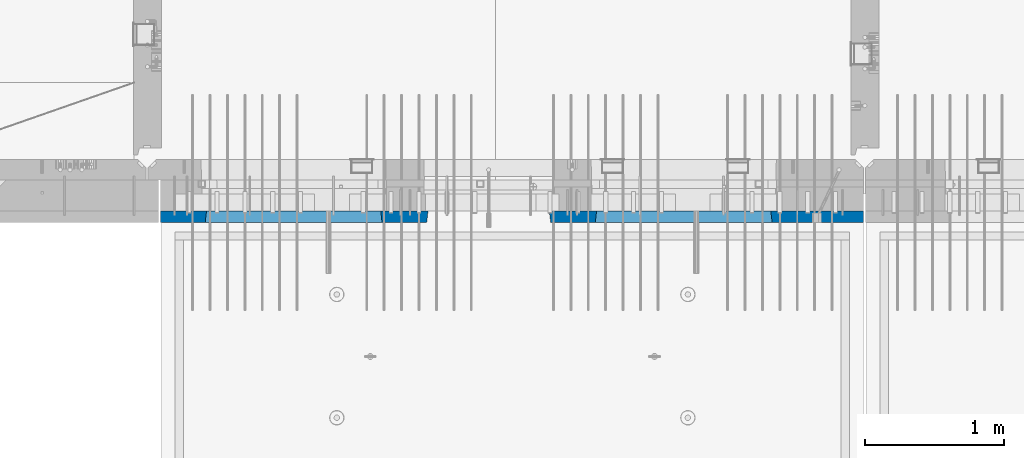
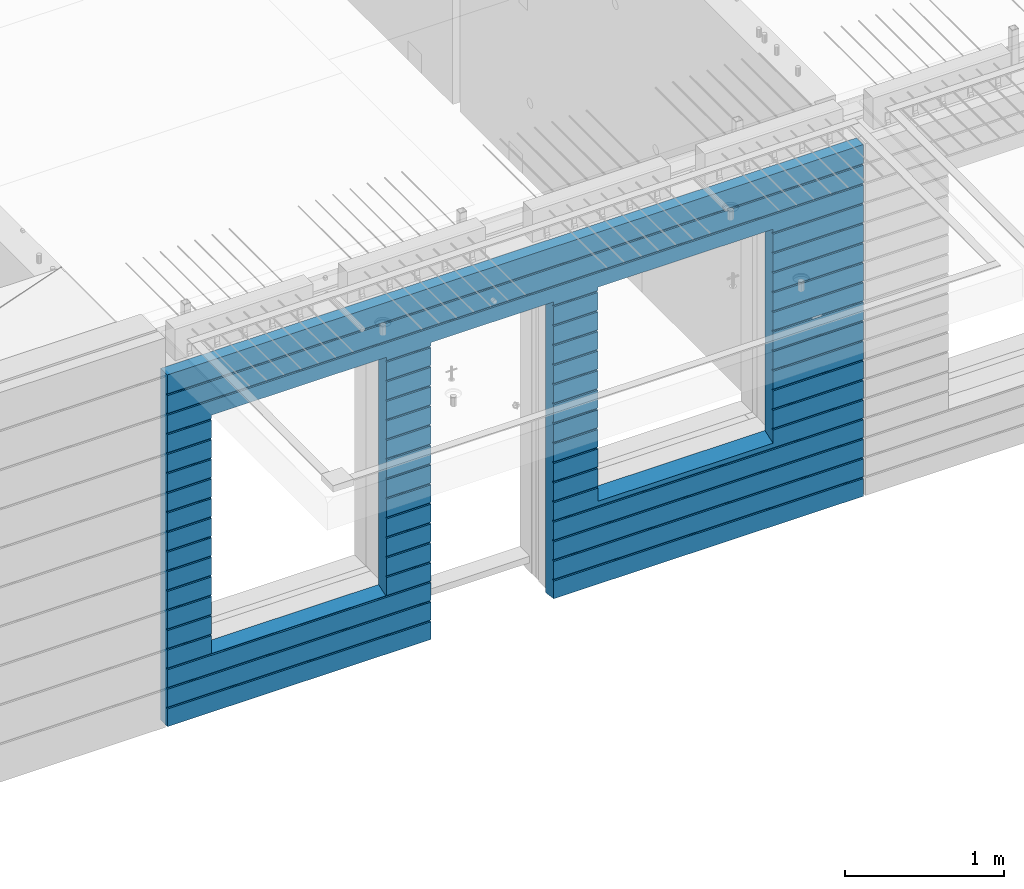
# One storey, part 222 of 341: 1 wall, 1 element without a shape of its own.
"""IFC2X3 building model written with IfcOpenShell, lengths in millimetres."""

import ifcopenshell
import ifcopenshell.guid

model = None  # the IFC model being written
_history = None  # IfcOwnerHistory: only IFC2X3 demands one
_inside = {}  # id of a spatial element -> (the spatial element, [elements in it])
_under = {}  # id of a project, library or spatial element -> (it, [spatial elements below it])
_declared = {}  # id of a project -> (the project, [libraries it declares])
_typed = {}  # id of a type object -> (the type object, [elements of that type])
_made_of = {}  # id of a material, layer set ... -> (it, [elements and type objects made of it])


def new_model(schema):
    """Start an empty IFC model of exactly this schema.

    Asked for "IFC4X3", IfcOpenShell would pick the latest addendum, in which some entities
    have other attributes; the version numbers below select the first issue.
    IFC2X3 requires an IfcOwnerHistory on every rooted entity: one is made here for all.
    """
    global model, _history
    if schema == "IFC4X3":
        model = ifcopenshell.file(schema_version=(4, 3, 0, 0))
    else:
        model = ifcopenshell.file(schema=schema)
    _inside.clear()
    _under.clear()
    _declared.clear()
    _typed.clear()
    _made_of.clear()
    _history = None
    if model.schema == "IFC2X3":
        org = make("IfcOrganization", Name="unknown")
        user = make(
            "IfcPersonAndOrganization",
            ThePerson=make("IfcPerson", FamilyName="unknown"),
            TheOrganization=org,
        )
        app = make(
            "IfcApplication",
            ApplicationDeveloper=org,
            Version="unknown",
            ApplicationFullName="unknown",
            ApplicationIdentifier="unknown",
        )
        _history = make(
            "IfcOwnerHistory",
            OwningUser=user,
            OwningApplication=app,
            ChangeAction="ADDED",
            CreationDate=0,
        )
    return model


def make(cls, **values):
    """One entity of the class cls with the attributes given. An attribute that is None is left unset."""
    return model.create_entity(
        cls, **{name: value for name, value in values.items() if value is not None}
    )


def rooted(cls, **values):
    """An entity with a GlobalId (a new one), such as an element, a storey or a relation."""
    return make(cls, GlobalId=ifcopenshell.guid.new(), OwnerHistory=_history, **values)


def si_unit(unit_type, name, prefix=None):
    """IfcSIUnit, for example si_unit("LENGTHUNIT", "METRE", prefix="MILLI")."""
    return make("IfcSIUnit", UnitType=unit_type, Prefix=prefix, Name=name)


def assignment(units):
    """IfcUnitAssignment: the units of a project."""
    return None if units is None else make("IfcUnitAssignment", Units=units)


def point(xyz):
    """IfcCartesianPoint."""
    return None if xyz is None else make("IfcCartesianPoint", Coordinates=xyz)


def direction(xyz):
    """IfcDirection."""
    return None if xyz is None else make("IfcDirection", DirectionRatios=xyz)


def frame(location, z_axis=None, x_axis=None):
    """IfcAxis2Placement3D, a coordinate frame: its origin and axes. An axis left out is left unset."""
    return make(
        "IfcAxis2Placement3D",
        Location=point(location),
        Axis=direction(z_axis),
        RefDirection=direction(x_axis),
    )


def origin_with_axes():
    """The frame at (0, 0, 0) with the z axis (0, 0, 1) and the x axis (1, 0, 0) written out."""
    return frame((0.0, 0.0, 0.0), z_axis=(0.0, 0.0, 1.0), x_axis=(1.0, 0.0, 0.0))


def place(relative_to, where):
    """IfcLocalPlacement: puts the frame where relative to a parent placement (None: the world)."""
    return make(
        "IfcLocalPlacement", PlacementRelTo=relative_to, RelativePlacement=where
    )


def context(
    kind, dimensions, precision=None, world=None, true_north=None, identifier=None
):
    """IfcGeometricRepresentationContext, for example the 3D "Model" context."""
    return make(
        "IfcGeometricRepresentationContext",
        ContextIdentifier=identifier,
        ContextType=kind,
        CoordinateSpaceDimension=dimensions,
        Precision=precision,
        WorldCoordinateSystem=world,
        TrueNorth=true_north,
    )


def subcontext(parent, identifier, kind, view, scale=None):
    """IfcGeometricRepresentationSubContext, for example "Body" below "Model"."""
    return make(
        "IfcGeometricRepresentationSubContext",
        ContextIdentifier=identifier,
        ContextType=kind,
        ParentContext=parent,
        TargetScale=scale,
        TargetView=view,
    )


def project(units=None, contexts=None):
    """IfcProject with its units and contexts."""
    return rooted(
        "IfcProject",
        Name="project",
        RepresentationContexts=contexts,
        UnitsInContext=assignment(units),
    )


def spatial(cls, under=None, at=None, **own):
    """A site, building, storey or space (cls), placed at a placement, below another one or the project."""
    s = rooted(cls, ObjectPlacement=at, **own)
    if under is not None:
        _under.setdefault(under.id(), (under, []))[1].append(s)
    return s


def faces_of(points, faces, orient=None, outer=None):
    """IfcFace entities. A face is a list of loops; a loop is a list of indices into points, from 0.

    orient and outer hold one flag for each loop. By default every Orientation is true, the
    first loop of a face is its IfcFaceOuterBound and the others are IfcFaceBound.
    """
    made = []
    for i, loops in enumerate(faces):
        bounds = []
        for j, loop in enumerate(loops):
            is_outer = j == 0 if outer is None else outer[i][j]
            bounds.append(
                make(
                    "IfcFaceOuterBound" if is_outer else "IfcFaceBound",
                    Bound=make("IfcPolyLoop", Polygon=[points[k] for k in loop]),
                    Orientation=True if orient is None else orient[i][j],
                )
            )
        made.append(make("IfcFace", Bounds=bounds))
    return made


def faceted_brep(points, faces, orient=None, outer=None, voids=None):
    """IfcFacetedBrep: a solid bounded by flat faces; with voids (closed shells), ...WithVoids."""
    shared = [point(p) for p in points]
    hull = make("IfcClosedShell", CfsFaces=faces_of(shared, faces, orient, outer))
    if voids is None:
        return make("IfcFacetedBrep", Outer=hull)
    return make(
        "IfcFacetedBrepWithVoids",
        Outer=hull,
        Voids=[
            make(cls, CfsFaces=faces_of(shared, fs, o, b)) for cls, fs, o, b in voids
        ],
    )


def shape(context_of_items, identifier, shape_type, items):
    """IfcShapeRepresentation: the items that make up one representation, for example the "Body"."""
    return make(
        "IfcShapeRepresentation",
        ContextOfItems=context_of_items,
        RepresentationIdentifier=identifier,
        RepresentationType=shape_type,
        Items=items,
    )


def material(Name=None, Category=None):
    """IfcMaterial."""
    return make("IfcMaterial", Name=Name, Category=Category)


def made_of(thing, what):
    """Note that an element or type object is made of a material, layer set ...; save() writes the relation."""
    if what is not None:
        _made_of.setdefault(what.id(), (what, []))[1].append(thing)
    return thing


def type_object(cls, material=None, **own):
    """A type object (cls), such as IfcWallType, which elements share."""
    return made_of(rooted(cls, **own), material)


def element(
    cls,
    number,
    at=None,
    inside=None,
    cuts=None,
    type_object=None,
    material=None,
    context=None,
    identifier="Body",
    shape_type=None,
    held_by="IfcProductDefinitionShape",
    body=None,
    shapes=None,
    **own,
):
    """One element of the class cls, such as IfcWall. Its Tag is "e" and its number.

    at: its placement. inside: the storey or other place that contains it. cuts: it is an
    opening in that element (IfcRelVoidsElement). A single representation is given by context,
    identifier, shape_type and body (its items); several are given by shapes. held_by: the class
    of the entity that holds the representations. save() writes the other relations.
    """
    e = rooted(cls, Tag="e%d" % number, ObjectPlacement=at, **own)
    if body is not None:
        shapes = [shape(context, identifier, shape_type, body)]
    if shapes is not None:
        e.Representation = make(held_by, Representations=shapes)
    if inside is not None:
        _inside.setdefault(inside.id(), (inside, []))[1].append(e)
    if cuts is not None:
        rooted(
            "IfcRelVoidsElement", RelatingBuildingElement=cuts, RelatedOpeningElement=e
        )
    if type_object is not None:
        _typed.setdefault(type_object.id(), (type_object, []))[1].append(e)
    return made_of(e, material)


def aggregate(whole, parts):
    """IfcRelAggregates: a whole, such as a stair, and the parts it consists of."""
    return rooted("IfcRelAggregates", RelatingObject=whole, RelatedObjects=parts)


def save(model, path):
    """Write the relations noted so far, then the file.

    IfcRelAggregates (storeys below a building ...), IfcRelContainedInSpatialStructure (elements
    in a storey), IfcRelDefinesByType, IfcRelAssociatesMaterial and IfcRelDeclares: one each for
    every whole, place, type object, material and project.
    """
    for whole, parts in _under.values():
        aggregate(whole, parts)
    for where, things in _inside.values():
        rooted(
            "IfcRelContainedInSpatialStructure",
            RelatedElements=things,
            RelatingStructure=where,
        )
    for kind, things in _typed.values():
        rooted("IfcRelDefinesByType", RelatedObjects=things, RelatingType=kind)
    for what, things in _made_of.values():
        rooted("IfcRelAssociatesMaterial", RelatedObjects=things, RelatingMaterial=what)
    for by, libraries in _declared.values():
        rooted("IfcRelDeclares", RelatingContext=by, RelatedDefinitions=libraries)
    model.write(path)


model = new_model("IFC2X3")

# Units and contexts
model_context = context("Model", 3, precision=1e-05, world=origin_with_axes())
body_context = subcontext(model_context, "Body", "Model", "MODEL_VIEW")
ifc_project = project(units=[si_unit("LENGTHUNIT", "METRE", prefix="MILLI"), si_unit("AREAUNIT", "SQUARE_METRE"), si_unit("VOLUMEUNIT", "CUBIC_METRE"), si_unit("MASSUNIT", "GRAM", prefix="KILO"), si_unit("TIMEUNIT", "SECOND"), si_unit("PLANEANGLEUNIT", "RADIAN"), si_unit("SOLIDANGLEUNIT", "STERADIAN"), si_unit("THERMODYNAMICTEMPERATUREUNIT", "DEGREE_CELSIUS"), si_unit("LUMINOUSINTENSITYUNIT", "LUMEN")], contexts=[model_context])

# Site, building, storey
site_placement = place(None, origin_with_axes())
site = spatial("IfcSite", under=ifc_project, at=site_placement, CompositionType="ELEMENT")
building_placement = place(site_placement, origin_with_axes())
building = spatial("IfcBuilding", under=site, at=building_placement, CompositionType="ELEMENT")
storey_placement = place(building_placement, origin_with_axes())
storey = spatial("IfcBuildingStorey", under=building, at=storey_placement, Name="5", CompositionType="ELEMENT", Elevation=0.0)

# Assembly, wall
assembly_placement = place(storey_placement, origin_with_axes())
assembly = element("IfcElementAssembly", 1, at=assembly_placement, inside=storey, AssemblyPlace="NOTDEFINED", PredefinedType="REINFORCEMENT_UNIT")
ifc_material = material(Name="CONCRETE/C30/37")
wall_type = type_object("IfcWallType", PredefinedType="NOTDEFINED")
wall_placement = place(assembly_placement, frame((21810.0, 7587.5, 95102.5), z_axis=(0.0, 0.0, 1.0), x_axis=(-1.0, 3.00000001838171e-08, 0.0)))
wall = element("IfcWall", 2, at=wall_placement, type_object=wall_type, material=ifc_material, context=body_context, shape_type="Brep", body=[
    faceted_brep([(3465.15088791894, 41.2121213860573, -911.742424344746), (3464.99937278789, 42.5, -912.5), (3464.99937278789, 42.5, -912.000000055254), (4734.84785765683, 41.2121213860573, -911.742424344746), (4734.99937278789, 42.5, -912.5), (4734.99937278789, 42.5, -912.000000055254), (10.0, 42.5, -1347.5), (10.0, 42.5, -1212.00000005524), (2254.99845837354, 42.5, -1212.00000005524), (2254.99845837354, 42.5, -1347.5), (10.0, 32.4999992501662, -1210.00000000079), (2256.17512512844, 32.4999992501662, -1210.00000000079), (10.0000007500639, 32.499999249937, -1200.00000000079), (2256.17512514468, 32.4999991121731, -1199.99999959956), (10.0, 42.5, -1198.00000011075), (2254.99845837354, 42.5, -1198.00000011075), (10.0, 42.5, -1062.00000005522), (2254.99845837354, 42.5, -1062.00000005522), (10.0, 32.4999992506964, -1060.00000000079), (2256.17512512838, 32.4999992506964, -1060.00000000079), (10.0000007500657, 32.499999249937, -1050.00000000079), (2256.17512514461, 32.499999112697, -1049.99999959956), (10.0, 42.5, -1048.00000011074), (2254.99845837354, 42.5, -1048.00000011074), (10.0, 42.5, -912.000000055254), (2254.99845837354, 42.5, -912.000000055254), (10.0, 32.4999992512312, -910.000000000815), (2256.17512512832, 32.4999992512312, -910.000000000815), (10.0000007500657, 32.499999249937, -900.000000000786), (2256.17512514455, 32.4999991132318, -899.99999959959), (10.0, 42.5, -898.000000110769), (2254.99845837354, 42.5, -898.000000110769), (10.0, 42.5, -762.000000055225), (2254.99845837354, 42.5, -762.000000055225), (10.0, 32.4999992517696, -760.000000000771), (2256.17512512825, 32.4999992517696, -760.000000000771), (10.0000007500657, 32.499999249937, -750.000000000786), (2256.17512514449, 32.4999991137747, -749.999999599546), (10.0, 42.5, -748.00000011074), (2254.99845837354, 42.5, -748.00000011074), (675.00013572734, 42.5, 927.5), (1925.00013572734, 42.5, 927.5), (1935.00013572734, 42.5, 927.5), (1925.00013572734, -42.5, 932.5), (675.00013572734, -42.5, 932.5), (665.00013572734, 42.5, 927.5), (665.00013572734, 42.5, -712.5), (675.00013572734, -42.5, -662.5), (1925.00013572734, -42.5, -662.5), (1935.00013572734, 42.5, -712.5), (1925.00013572734, -42.5, 927.5), (1935.00013572734, 42.5, 901.999999889245), (1933.82366503463, 32.4999991119776, 900.000000400425), (1933.82366505087, 32.4999992499834, 889.9999999992), (1935.00013572734, 42.5, 887.999999944761), (1935.00013572734, 42.5, 751.999999889245), (1933.82366503463, 32.4999991119885, 750.000000400425), (1933.82366505087, 32.4999992499925, 739.9999999992), (1935.00013572734, 42.5, 737.999999944761), (1935.00013572734, 42.5, 601.99999988926), (1933.82366503463, 32.4999991120112, 600.00000040044), (1933.82366505087, 32.4999992500152, 589.999999999214), (1935.00013572734, 42.5, 587.999999944775), (1935.00013572734, 42.5, 451.999999889245), (1933.82366503464, 32.4999991120167, 450.000000400425), (1933.82366505087, 32.4999992500216, 439.9999999992), (1935.00013572734, 42.5, 437.999999944761), (1935.00013572734, 42.5, 301.999999889245), (1933.82366503464, 32.4999991120312, 300.000000400425), (1933.82366505087, 32.4999992500352, 289.9999999992), (1935.00013572734, 42.5, 287.999999944761), (1935.00013572734, 42.5, 151.999999889245), (1933.82366503464, 32.4999991120421, 150.000000400425), (1933.82366505088, 32.499999250047, 139.9999999992), (1935.00013572734, 42.5, 137.999999944761), (1935.00013572734, 42.5, 1.99999988923082), (1933.82366503515, 32.4999991164286, 4.00410499423742e-07), (1933.82366505139, 32.4999992544263, -10.0000000008149), (1935.00013572734, 42.5, -12.0000000552536), (1935.00013572734, 42.5, -148.000000110755), (1933.82366503509, 32.4999991158993, -149.99999959956), (1933.82366505132, 32.4999992538915, -160.000000000786), (1935.00013572734, 42.5, -162.000000055239), (1935.00013572734, 42.5, -298.000000110755), (1933.82366503503, 32.49999911536, -299.999999599575), (1933.82366505126, 32.4999992533594, -310.0000000008), (1935.00013572734, 42.5, -312.000000055239), (1935.00013572734, 42.5, -448.00000011074), (1933.82366503496, 32.4999991148343, -449.99999959956), (1933.8236650512, 32.4999992528337, -460.000000000786), (1935.00013572734, 42.5, -462.000000055225), (1935.00013572734, 42.5, -598.000000110755), (1933.8236650349, 32.499999114295, -599.999999599575), (1933.82366505114, 32.4999992522935, -610.0000000008), (1935.00013572734, 42.5, -612.000000055239), (2256.1751251447, 32.4999991119776, 900.000000400425), (2256.17512512846, 32.4999992499834, 889.9999999992), (2254.99845837354, 42.5, 887.999999944761), (2254.99845837354, 42.5, 751.999999889245), (2256.17512514469, 32.4999991119885, 750.000000400425), (2256.17512512846, 32.4999992499925, 739.9999999992), (2254.99845837354, 42.5, 737.999999944761), (2254.99845837354, 42.5, 601.99999988926), (2256.17512514469, 32.4999991120112, 600.00000040044), (2256.17512512846, 32.4999992500152, 589.999999999214), (2254.99845837354, 42.5, 587.999999944775), (2254.99845837354, 42.5, 451.999999889245), (2256.17512514469, 32.4999991120167, 450.000000400425), (2256.17512512846, 32.4999992500216, 439.9999999992), (2254.99845837354, 42.5, 437.999999944761), (2254.99845837354, 42.5, 301.999999889245), (2256.17512514469, 32.4999991120312, 300.000000400425), (2256.17512512846, 32.4999992500352, 289.9999999992), (2254.99845837354, 42.5, 287.999999944761), (2254.99845837354, 42.5, 151.999999889245), (2256.17512514469, 32.4999991120421, 150.000000400425), (2256.17512512846, 32.499999250047, 139.9999999992), (2254.99845837354, 42.5, 137.999999944761), (2254.99845837354, 42.5, 1.99999988923082), (2256.17512514417, 32.4999991164286, 4.00410499423742e-07), (2256.17512512794, 32.4999992544263, -10.0000000008149), (2254.99845837354, 42.5, -12.0000000552536), (2254.99845837354, 42.5, -148.000000110755), (2256.17512514424, 32.4999991158993, -149.99999959956), (2256.175125128, 32.4999992538915, -160.000000000786), (2254.99845837354, 42.5, -162.000000055239), (2254.99845837354, 42.5, -298.000000110755), (2256.1751251443, 32.49999911536, -299.999999599575), (2256.17512512806, 32.4999992533594, -310.0000000008), (2254.99845837354, 42.5, -312.000000055239), (2254.99845837354, 42.5, -448.00000011074), (2256.17512514436, 32.4999991148343, -449.99999959956), (2256.17512512813, 32.4999992528337, -460.000000000786), (2254.99845837354, 42.5, -462.000000055225), (2254.99845837354, 42.5, -598.000000110755), (2256.17512514443, 32.499999114295, -599.999999599575), (2256.17512512819, 32.4999992522935, -610.0000000008), (2254.99845837354, 42.5, -612.000000055239), (10.0, 42.5, -612.000000055239), (665.00013572734, 42.5, -612.000000055239), (10.0, 32.4999992522935, -610.0000000008), (666.176606403544, 32.4999992522935, -610.0000000008), (10.0000007500657, 32.499999249937, -600.000000000786), (666.176606419776, 32.499999114295, -599.999999599575), (10.0, 42.5, -598.000000110755), (665.00013572734, 42.5, -598.000000110755), (10.0, 42.5, -462.000000055225), (665.00013572734, 42.5, -462.000000055225), (10.0, 32.4999992528337, -460.000000000786), (666.176606403482, 32.4999992528337, -460.000000000786), (10.0000007500657, 32.499999249937, -450.000000000786), (666.176606419715, 32.4999991148343, -449.99999959956), (10.0, 42.5, -448.00000011074), (665.00013572734, 42.5, -448.00000011074), (10.0, 42.5, -312.000000055239), (665.00013572734, 42.5, -312.000000055239), (10.0, 32.4999992533594, -310.0000000008), (666.17660640342, 32.4999992533594, -310.0000000008), (10.0000007500657, 32.499999249937, -300.000000000786), (666.176606419653, 32.49999911536, -299.999999599575), (10.0, 42.5, -298.000000110755), (665.00013572734, 42.5, -298.000000110755), (10.0, 42.5, -162.000000055239), (665.00013572734, 42.5, -162.000000055239), (10.0, 32.4999992538915, -160.000000000786), (666.176606403355, 32.4999992538915, -160.000000000786), (10.0000007500657, 32.499999249937, -150.000000000786), (666.176606419591, 32.4999991158993, -149.99999959956), (10.0, 42.5, -148.000000110755), (665.00013572734, 42.5, -148.000000110755), (10.0, 42.5, -12.0000000552536), (665.00013572734, 42.5, -12.0000000552536), (10.0, 32.4999992544263, -10.0000000008149), (666.176606403293, 32.4999992544263, -10.0000000008149), (10.0000007500657, 32.499999249937, -7.8580342233181e-10), (666.176606419529, 32.4999991164286, 4.00410499423742e-07), (10.0, 42.5, 1.99999988923082), (665.00013572734, 42.5, 1.99999988923082), (10.0, 42.5, 137.999999944761), (665.00013572734, 42.5, 137.999999944761), (10.0, 32.499999250047, 139.9999999992), (666.176606403806, 32.499999250047, 139.9999999992), (10.0000007500657, 32.499999249937, 149.999999999214), (666.176606420046, 32.4999991120421, 150.000000400425), (10.0, 42.5, 151.999999889245), (665.00013572734, 42.5, 151.999999889245), (10.0, 42.5, 287.999999944761), (665.00013572734, 42.5, 287.999999944761), (10.0, 32.4999992500352, 289.9999999992), (666.176606403809, 32.4999992500352, 289.9999999992), (10.0000007500657, 32.499999249937, 299.999999999214), (666.176606420046, 32.4999991120312, 300.000000400425), (10.0, 42.5, 301.999999889245), (665.00013572734, 42.5, 301.999999889245), (10.0, 42.5, 437.999999944761), (665.00013572734, 42.5, 437.999999944761), (10.0, 32.4999992500216, 439.9999999992), (666.176606403809, 32.4999992500216, 439.9999999992), (10.0000007500657, 32.499999249937, 449.999999999214), (666.176606420046, 32.4999991120167, 450.000000400425), (10.0, 42.5, 451.999999889245), (665.00013572734, 42.5, 451.999999889245), (10.0, 42.5, 587.999999944775), (665.00013572734, 42.5, 587.999999944775), (10.0, 32.4999992500152, 589.999999999214), (666.176606403809, 32.4999992500152, 589.999999999214), (10.0000007500657, 32.499999249937, 599.999999999214), (666.176606420049, 32.4999991120112, 600.00000040044), (10.0, 42.5, 601.99999988926), (665.00013572734, 42.5, 601.99999988926), (10.0, 42.5, 737.999999944761), (665.00013572734, 42.5, 737.999999944761), (9.99999999999636, 32.4999992499925, 739.9999999992), (666.176606403813, 32.4999992499925, 739.9999999992), (10.0000007500657, 32.499999249937, 749.999999999214), (666.176606420049, 32.4999991119885, 750.000000400425), (10.0, 42.5, 751.999999889245), (665.00013572734, 42.5, 751.999999889245), (10.0, 42.5, 887.999999944761), (665.00013572734, 42.5, 887.999999944761), (10.0, 32.4999992499834, 889.9999999992), (666.176606403813, 32.4999992499834, 889.9999999992), (10.0000007500657, 32.499999249937, 899.999999999214), (666.176606420053, 32.4999991119776, 900.000000400425), (675.00013572734, -42.5, 927.5), (665.00013572734, 42.5, 901.999999889245), (10.0, 42.5, 901.999999889245), (10.0, 42.5, 1051.99999988925), (5055.0, 42.5, 1051.99999988925), (5055.0, 32.4999991119666, 1050.00000040043), (10.0000007500657, 32.499999249937, 1049.99999999921), (5055.0, 32.4999992499706, 1039.9999999992), (10.0, 32.4999992499706, 1039.9999999992), (5055.0, 42.5, 1037.99999994476), (10.0, 42.5, 1037.99999994476), (5055.0, 42.5, 901.999999889245), (5055.0, 32.4999991119776, 900.000000400425), (4733.82290209518, 32.4999991119776, 900.000000400425), (4734.99937278789, 42.5, 901.999999889245), (5055.0, 32.4999992499834, 889.9999999992), (4733.82290211141, 32.4999992499834, 889.9999999992), (5055.0, 42.5, 887.999999944761), (4734.99937278789, 42.5, 887.999999944761), (5055.0, 42.5, 751.999999889245), (4734.99937278789, 42.5, 751.999999889245), (5055.0, 32.4999991119885, 750.000000400425), (4733.82290209518, 32.4999991119885, 750.000000400425), (5055.0, 32.4999992499925, 739.9999999992), (4733.82290211142, 32.4999992499925, 739.9999999992), (5055.0, 42.5, 737.999999944761), (4734.99937278789, 42.5, 737.999999944761), (5055.0, 42.5, 601.99999988926), (4734.99937278789, 42.5, 601.99999988926), (5055.0, 32.4999991120112, 600.00000040044), (4733.82290209518, 32.4999991120112, 600.00000040044), (5055.0, 32.4999992500152, 589.999999999214), (4733.82290211142, 32.4999992500152, 589.999999999214), (5055.0, 42.5, 587.999999944775), (4734.99937278789, 42.5, 587.999999944775), (5055.0, 42.5, 451.999999889245), (4734.99937278789, 42.5, 451.999999889245), (5055.0, 32.4999991120167, 450.000000400425), (4733.82290209518, 32.4999991120167, 450.000000400425), (5055.0, 32.4999992500216, 439.9999999992), (4733.82290211142, 32.4999992500216, 439.9999999992), (5055.0, 42.5, 437.999999944761), (4734.99937278789, 42.5, 437.999999944761), (5055.0, 42.5, 301.999999889245), (4734.99937278789, 42.5, 301.999999889245), (5055.0, 32.4999991120312, 300.000000400425), (4733.82290209518, 32.4999991120312, 300.000000400425), (5055.0, 32.4999992500352, 289.9999999992), (4733.82290211142, 32.4999992500352, 289.9999999992), (5055.0, 42.5, 287.999999944761), (4734.99937278789, 42.5, 287.999999944761), (5055.0, 42.5, 151.999999889245), (4734.99937278789, 42.5, 151.999999889245), (5055.0, 32.4999991120421, 150.000000400425), (4733.82290209519, 32.4999991120421, 150.000000400425), (5055.0, 32.499999250047, 139.9999999992), (4733.82290211142, 32.499999250047, 139.9999999992), (5055.0, 42.5, 137.999999944761), (4734.99937278789, 42.5, 137.999999944761), (5055.0, 42.5, 1.99999988923082), (4734.99937278789, 42.5, 1.99999988923082), (5055.0, 32.4999991164286, 4.00410499423742e-07), (4733.8229020957, 32.4999991164286, 4.00410499423742e-07), (5055.0, 32.4999992544263, -10.0000000008149), (4733.82290211194, 32.4999992544263, -10.0000000008149), (5055.0, 42.5, -12.0000000552536), (4734.99937278789, 42.5, -12.0000000552536), (5055.0, 42.5, -148.000000110755), (4734.99937278789, 42.5, -148.000000110755), (5055.0, 32.4999991158993, -149.99999959956), (4733.82290209564, 32.4999991158993, -149.99999959956), (5055.0, 32.4999992538915, -160.000000000786), (4733.82290211188, 32.4999992538915, -160.000000000786), (5055.0, 42.5, -162.000000055239), (4734.99937278789, 42.5, -162.000000055239), (5055.0, 42.5, -298.000000110755), (4734.99937278789, 42.5, -298.000000110755), (5055.0, 32.49999911536, -299.999999599575), (4733.82290209558, 32.49999911536, -299.999999599575), (5055.0, 32.4999992533594, -310.0000000008), (4733.82290211181, 32.4999992533594, -310.0000000008), (5055.0, 42.5, -312.000000055239), (4734.99937278789, 42.5, -312.000000055239), (5055.0, 42.5, -448.00000011074), (4734.99937278789, 42.5, -448.00000011074), (5055.0, 32.4999991148343, -449.99999959956), (4733.82290209552, 32.4999991148343, -449.99999959956), (5055.0, 32.4999992528337, -460.000000000786), (4733.82290211175, 32.4999992528337, -460.000000000786), (5055.0, 42.5, -462.000000055225), (4734.99937278789, 42.5, -462.000000055225), (5055.0, 42.5, -598.000000110755), (4734.99937278789, 42.5, -598.000000110755), (5055.0, 32.499999114295, -599.999999599575), (4733.82290209545, 32.499999114295, -599.999999599575), (5055.0, 32.4999992522935, -610.0000000008), (4733.82290211169, 32.4999992522935, -610.0000000008), (5055.0, 42.5, -612.000000055239), (4734.99937278789, 42.5, -612.000000055239), (5055.0, 42.5, -748.00000011074), (4734.99937278789, 42.5, -748.00000011074), (5055.0, 32.4999991137747, -749.999999599546), (4733.82290209539, 32.4999991137747, -749.999999599546), (5055.0, 32.4999992517696, -760.000000000771), (4733.82290211162, 32.4999992517696, -760.000000000771), (5055.0, 42.5, -762.000000055225), (4734.99937278789, 42.5, -762.000000055225), (5055.0, 42.5, -898.000000110769), (4734.99937278789, 42.5, -898.000000110769), (5055.0, 32.4999991132318, -899.99999959959), (4733.82290209533, 32.4999991132318, -899.99999959959), (3466.1758434697, 32.499999204555, -906.617646590923), (3474.99937278789, -42.5, -862.5), (4724.99937278789, -42.5, -862.5), (4733.82290210607, 32.499999204555, -906.617646590923), (4724.99937278789, -42.5, 927.5), (4724.99937278789, -42.5, 932.5), (4734.99937278789, 42.5, 927.5), (2265.00051719707, 42.5, 927.5), (3135.00051719707, 42.5, 927.5), (3144.99845837354, 42.5, 927.5), (3134.99679170688, -42.5, 932.502857142856), (2265.00012504021, -42.5, 932.502857142856), (2254.99845837354, 42.5, 927.5), (4724.99937278789, 42.5, 927.5), (3474.99937278789, 42.5, 927.5), (3464.99937278789, 42.5, 927.5), (3464.99937278789, 42.5, 901.999999889245), (3144.99845837354, 42.5, 901.999999889245), (2254.99845837354, 42.5, 901.999999889245), (2265.00012504021, -42.5, 927.5), (2265.00012504021, -42.5, -1347.5), (10.0, -42.5, -1347.5), (10.0, 42.5, 1347.5), (10.0, -42.5, 1347.5), (5055.0, -42.5, 1347.5), (5055.0, 42.5, 1347.5), (5055.0, 42.5, 1201.99999988925), (10.0, 42.5, 1201.99999988925), (10.0, 42.5, 1187.99999994476), (10.0000007500657, 32.499999249937, 1199.99999999921), (9.99999999999636, 32.4999992499606, 1189.9999999992), (5055.0, 42.5, 1187.99999994476), (5055.0, 32.4999992499606, 1189.9999999992), (5055.0, 32.4999991119566, 1200.00000040043), (5055.0, -42.5, -1347.5), (5055.0, 42.5, -1347.5), (5055.0, 42.5, -1212.00000005524), (5055.0, 32.4999992501662, -1210.00000000079), (5055.0, 32.4999991121731, -1199.99999959956), (5055.0, 42.5, -1198.00000011075), (5055.0, 42.5, -1062.00000005522), (5055.0, 32.4999992506964, -1060.00000000079), (5055.0, 32.499999112697, -1049.99999959956), (5055.0, 42.5, -1048.00000011074), (5055.0, 42.5, -912.000000055254), (5055.0, 32.4999992512312, -910.000000000815), (3144.99845837354, 42.5, -1212.00000005524), (3143.82179161865, 32.4999992501662, -1210.00000000079), (3143.82179160241, 32.4999991121731, -1199.99999959956), (3144.99845837354, 42.5, -1198.00000011075), (3144.99845837354, 42.5, -1062.00000005522), (3143.82179161871, 32.4999992506964, -1060.00000000079), (3143.82179160247, 32.499999112697, -1049.99999959956), (3144.99845837354, 42.5, -1048.00000011074), (3144.99845837354, 42.5, -912.000000055254), (3143.82179161877, 32.4999992512312, -910.000000000815), (3466.17584348045, 32.4999991132318, -899.99999959959), (3143.82179160253, 32.4999991132318, -899.99999959959), (3464.99937278789, 42.5, -898.000000110769), (3144.99845837354, 42.5, -898.000000110769), (3464.99937278789, 42.5, -762.000000055225), (3144.99845837354, 42.5, -762.000000055225), (3466.17584346415, 32.4999992517696, -760.000000000771), (3143.82179161884, 32.4999992517696, -760.000000000771), (3466.17584348039, 32.4999991137747, -749.999999599546), (3143.8217916026, 32.4999991137747, -749.999999599546), (3464.99937278789, 42.5, -748.00000011074), (3144.99845837354, 42.5, -748.00000011074), (3464.99937278789, 42.5, -612.000000055239), (3144.99845837354, 42.5, -612.000000055239), (3466.17584346409, 32.4999992522935, -610.0000000008), (3143.8217916189, 32.4999992522935, -610.0000000008), (3466.17584348032, 32.499999114295, -599.999999599575), (3143.82179160266, 32.499999114295, -599.999999599575), (3464.99937278789, 42.5, -598.000000110755), (3144.99845837354, 42.5, -598.000000110755), (3464.99937278789, 42.5, -462.000000055225), (3144.99845837354, 42.5, -462.000000055225), (3466.17584346403, 32.4999992528337, -460.000000000786), (3143.82179161896, 32.4999992528337, -460.000000000786), (3466.17584348026, 32.4999991148343, -449.99999959956), (3143.82179160272, 32.4999991148343, -449.99999959956), (3464.99937278789, 42.5, -448.00000011074), (3144.99845837354, 42.5, -448.00000011074), (3464.99937278789, 42.5, -312.000000055239), (3144.99845837354, 42.5, -312.000000055239), (3466.17584346396, 32.4999992533594, -310.0000000008), (3143.82179161902, 32.4999992533594, -310.0000000008), (3466.1758434802, 32.49999911536, -299.999999599575), (3143.82179160278, 32.49999911536, -299.999999599575), (3464.99937278789, 42.5, -298.000000110755), (3144.99845837354, 42.5, -298.000000110755), (3464.99937278789, 42.5, -162.000000055239), (3144.99845837354, 42.5, -162.000000055239), (3466.1758434639, 32.4999992538915, -160.000000000786), (3143.82179161909, 32.4999992538915, -160.000000000786), (3466.17584348014, 32.4999991158993, -149.99999959956), (3143.82179160284, 32.4999991158993, -149.99999959956), (3464.99937278789, 42.5, -148.000000110755), (3144.99845837354, 42.5, -148.000000110755), (3464.99937278789, 42.5, -12.0000000552536), (3144.99845837354, 42.5, -12.0000000552536), (3466.17584346384, 32.4999992544263, -10.0000000008149), (3143.82179161915, 32.4999992544263, -10.0000000008149), (3466.17584348008, 32.4999991164286, 4.00410499423742e-07), (3143.82179160291, 32.4999991164286, 4.00410499423742e-07), (3464.99937278789, 42.5, 1.99999988923082), (3144.99845837354, 42.5, 1.99999988923082), (3464.99937278789, 42.5, 137.999999944761), (3144.99845837354, 42.5, 137.999999944761), (3466.17584346435, 32.499999250047, 139.9999999992), (3143.82179161863, 32.499999250047, 139.9999999992), (3466.17584348059, 32.4999991120421, 150.000000400425), (3143.82179160239, 32.4999991120421, 150.000000400425), (3464.99937278789, 42.5, 151.999999889245), (3144.99845837354, 42.5, 151.999999889245), (3464.99937278789, 42.5, 287.999999944761), (3144.99845837354, 42.5, 287.999999944761), (3466.17584346436, 32.4999992500352, 289.9999999992), (3143.82179161863, 32.4999992500352, 289.9999999992), (3466.17584348059, 32.4999991120312, 300.000000400425), (3143.82179160239, 32.4999991120312, 300.000000400425), (3464.99937278789, 42.5, 301.999999889245), (3144.99845837354, 42.5, 301.999999889245), (3464.99937278789, 42.5, 437.999999944761), (3144.99845837354, 42.5, 437.999999944761), (3466.17584346436, 32.4999992500216, 439.9999999992), (3143.82179161863, 32.4999992500216, 439.9999999992), (3466.17584348059, 32.4999991120167, 450.000000400425), (3143.82179160239, 32.4999991120167, 450.000000400425), (3464.99937278789, 42.5, 451.999999889245), (3144.99845837354, 42.5, 451.999999889245), (3464.99937278789, 42.5, 587.999999944775), (3144.99845837354, 42.5, 587.999999944775), (3466.17584346436, 32.4999992500152, 589.999999999214), (3143.82179161863, 32.4999992500152, 589.999999999214), (3466.1758434806, 32.4999991120112, 600.00000040044), (3143.82179160239, 32.4999991120112, 600.00000040044), (3464.99937278789, 42.5, 601.99999988926), (3144.99845837354, 42.5, 601.99999988926), (3464.99937278789, 42.5, 737.999999944761), (3144.99845837354, 42.5, 737.999999944761), (3466.17584346436, 32.4999992499925, 739.9999999992), (3143.82179161863, 32.4999992499925, 739.9999999992), (3466.1758434806, 32.4999991119885, 750.000000400425), (3143.82179160239, 32.4999991119885, 750.000000400425), (3464.99937278789, 42.5, 751.999999889245), (3144.99845837354, 42.5, 751.999999889245), (3464.99937278789, 42.5, 887.999999944761), (3144.99845837354, 42.5, 887.999999944761), (3466.17584346436, 32.4999992499834, 889.9999999992), (3143.82179161863, 32.4999992499834, 889.9999999992), (3466.1758434806, 32.4999991119776, 900.000000400425), (3143.82179160239, 32.4999991119776, 900.000000400425), (3474.99937278789, -42.5, 932.5), (3474.99937278789, -42.5, 927.5), (3134.99679170688, -42.5, 927.5), (3134.99679170688, -42.5, -1347.5), (3144.99845837354, 42.5, -1347.5)], [[[0, 1, 2]], [[3, 4, 1, 0]], [[5, 4, 3]], [[6, 7, 8, 9]], [[7, 10, 11, 8]], [[10, 12, 13, 11]], [[12, 14, 15, 13]], [[14, 16, 17, 15]], [[16, 18, 19, 17]], [[18, 20, 21, 19]], [[20, 22, 23, 21]], [[22, 24, 25, 23]], [[24, 26, 27, 25]], [[26, 28, 29, 27]], [[28, 30, 31, 29]], [[30, 32, 33, 31]], [[32, 34, 35, 33]], [[34, 36, 37, 35]], [[36, 38, 39, 37]], [[40, 41, 42, 43, 44, 45]], [[46, 47, 48, 49]], [[50, 43, 42, 51, 52, 53, 54, 55, 56, 57, 58, 59, 60, 61, 62, 63, 64, 65, 66, 67, 68, 69, 70, 71, 72, 73, 74, 75, 76, 77, 78, 79, 80, 81, 82, 83, 84, 85, 86, 87, 88, 89, 90, 91, 92, 93, 94, 49, 48]], [[53, 52, 95, 96]], [[54, 53, 96, 97]], [[55, 54, 97, 98]], [[56, 55, 98, 99]], [[57, 56, 99, 100]], [[58, 57, 100, 101]], [[59, 58, 101, 102]], [[60, 59, 102, 103]], [[61, 60, 103, 104]], [[62, 61, 104, 105]], [[63, 62, 105, 106]], [[64, 63, 106, 107]], [[65, 64, 107, 108]], [[66, 65, 108, 109]], [[67, 66, 109, 110]], [[68, 67, 110, 111]], [[69, 68, 111, 112]], [[70, 69, 112, 113]], [[71, 70, 113, 114]], [[72, 71, 114, 115]], [[73, 72, 115, 116]], [[74, 73, 116, 117]], [[75, 74, 117, 118]], [[76, 75, 118, 119]], [[77, 76, 119, 120]], [[78, 77, 120, 121]], [[79, 78, 121, 122]], [[80, 79, 122, 123]], [[81, 80, 123, 124]], [[82, 81, 124, 125]], [[83, 82, 125, 126]], [[84, 83, 126, 127]], [[85, 84, 127, 128]], [[86, 85, 128, 129]], [[87, 86, 129, 130]], [[88, 87, 130, 131]], [[89, 88, 131, 132]], [[90, 89, 132, 133]], [[91, 90, 133, 134]], [[92, 91, 134, 135]], [[93, 92, 135, 136]], [[94, 93, 136, 137]], [[38, 138, 139, 46, 49, 94, 137, 39]], [[138, 140, 141, 139]], [[140, 142, 143, 141]], [[142, 144, 145, 143]], [[144, 146, 147, 145]], [[146, 148, 149, 147]], [[148, 150, 151, 149]], [[150, 152, 153, 151]], [[152, 154, 155, 153]], [[154, 156, 157, 155]], [[156, 158, 159, 157]], [[158, 160, 161, 159]], [[160, 162, 163, 161]], [[162, 164, 165, 163]], [[164, 166, 167, 165]], [[166, 168, 169, 167]], [[168, 170, 171, 169]], [[170, 172, 173, 171]], [[172, 174, 175, 173]], [[174, 176, 177, 175]], [[176, 178, 179, 177]], [[178, 180, 181, 179]], [[180, 182, 183, 181]], [[182, 184, 185, 183]], [[184, 186, 187, 185]], [[186, 188, 189, 187]], [[188, 190, 191, 189]], [[190, 192, 193, 191]], [[192, 194, 195, 193]], [[194, 196, 197, 195]], [[196, 198, 199, 197]], [[198, 200, 201, 199]], [[200, 202, 203, 201]], [[202, 204, 205, 203]], [[204, 206, 207, 205]], [[206, 208, 209, 207]], [[208, 210, 211, 209]], [[210, 212, 213, 211]], [[212, 214, 215, 213]], [[214, 216, 217, 215]], [[216, 218, 219, 217]], [[218, 220, 221, 219]], [[220, 222, 223, 221]], [[45, 44, 224, 47, 46, 139, 141, 143, 145, 147, 149, 151, 153, 155, 157, 159, 161, 163, 165, 167, 169, 171, 173, 175, 177, 179, 181, 183, 185, 187, 189, 191, 193, 195, 197, 199, 201, 203, 205, 207, 209, 211, 213, 215, 217, 219, 221, 223, 225]], [[222, 226, 225, 223]], [[227, 228, 229, 230]], [[230, 229, 231, 232]], [[232, 231, 233, 234]], [[235, 236, 237, 238]], [[236, 239, 240, 237]], [[239, 241, 242, 240]], [[241, 243, 244, 242]], [[243, 245, 246, 244]], [[245, 247, 248, 246]], [[247, 249, 250, 248]], [[249, 251, 252, 250]], [[251, 253, 254, 252]], [[253, 255, 256, 254]], [[255, 257, 258, 256]], [[257, 259, 260, 258]], [[259, 261, 262, 260]], [[261, 263, 264, 262]], [[263, 265, 266, 264]], [[265, 267, 268, 266]], [[267, 269, 270, 268]], [[269, 271, 272, 270]], [[271, 273, 274, 272]], [[273, 275, 276, 274]], [[275, 277, 278, 276]], [[277, 279, 280, 278]], [[279, 281, 282, 280]], [[281, 283, 284, 282]], [[283, 285, 286, 284]], [[285, 287, 288, 286]], [[287, 289, 290, 288]], [[289, 291, 292, 290]], [[291, 293, 294, 292]], [[293, 295, 296, 294]], [[295, 297, 298, 296]], [[297, 299, 300, 298]], [[299, 301, 302, 300]], [[301, 303, 304, 302]], [[303, 305, 306, 304]], [[305, 307, 308, 306]], [[307, 309, 310, 308]], [[309, 311, 312, 310]], [[311, 313, 314, 312]], [[313, 315, 316, 314]], [[315, 317, 318, 316]], [[317, 319, 320, 318]], [[319, 321, 322, 320]], [[321, 323, 324, 322]], [[323, 325, 326, 324]], [[325, 327, 328, 326]], [[327, 329, 330, 328]], [[329, 331, 332, 330]], [[331, 333, 334, 332]], [[335, 336, 337, 338]], [[339, 340, 341, 238, 237, 240, 242, 244, 246, 248, 250, 252, 254, 256, 258, 260, 262, 264, 266, 268, 270, 272, 274, 276, 278, 280, 282, 284, 286, 288, 290, 292, 294, 296, 298, 300, 302, 304, 306, 308, 310, 312, 314, 316, 318, 320, 322, 324, 326, 328, 330, 332, 334, 338, 337]], [[342, 343, 344, 345, 346, 347]], [[51, 42, 41, 40, 45, 225, 226, 234, 233, 235, 238, 341, 348, 349, 350, 351, 352, 344, 343, 342, 347, 353]], [[52, 51, 353, 95]], [[347, 346, 354, 355, 9, 8, 11, 13, 15, 17, 19, 21, 23, 25, 27, 29, 31, 33, 35, 37, 39, 137, 136, 135, 134, 133, 132, 131, 130, 129, 128, 127, 126, 125, 124, 123, 122, 121, 120, 119, 118, 117, 116, 115, 114, 113, 112, 111, 110, 109, 108, 107, 106, 105, 104, 103, 102, 101, 100, 99, 98, 97, 96, 95, 353]], [[356, 6, 9, 355]], [[357, 358, 359, 360]], [[357, 360, 361, 362]], [[363, 227, 230, 232, 234, 226, 222, 220, 218, 216, 214, 212, 210, 208, 206, 204, 202, 200, 198, 196, 194, 192, 190, 188, 186, 184, 182, 180, 178, 176, 174, 172, 170, 168, 166, 164, 162, 160, 158, 156, 154, 152, 150, 148, 146, 144, 142, 140, 138, 38, 36, 34, 32, 30, 28, 26, 24, 22, 20, 18, 16, 14, 12, 10, 7, 6, 356, 358, 357, 362, 364, 365]], [[228, 227, 363, 366]], [[365, 367, 366, 363]], [[364, 368, 367, 365]], [[362, 361, 368, 364]], [[360, 359, 369, 370, 371, 372, 373, 374, 375, 376, 377, 378, 379, 380, 333, 331, 329, 327, 325, 323, 321, 319, 317, 315, 313, 311, 309, 307, 305, 303, 301, 299, 297, 295, 293, 291, 289, 287, 285, 283, 281, 279, 277, 275, 273, 271, 269, 267, 265, 263, 261, 259, 257, 255, 253, 251, 249, 247, 245, 243, 241, 239, 236, 235, 233, 231, 229, 228, 366, 367, 368, 361]], [[372, 371, 381, 382]], [[373, 372, 382, 383]], [[374, 373, 383, 384]], [[375, 374, 384, 385]], [[376, 375, 385, 386]], [[377, 376, 386, 387]], [[378, 377, 387, 388]], [[2, 1, 4, 5, 379, 378, 388, 389]], [[380, 379, 5, 3, 0, 2, 389, 390]], [[391, 335, 338, 334, 333, 380, 390, 392]], [[393, 391, 392, 394]], [[395, 393, 394, 396]], [[397, 395, 396, 398]], [[399, 397, 398, 400]], [[401, 399, 400, 402]], [[403, 401, 402, 404]], [[405, 403, 404, 406]], [[407, 405, 406, 408]], [[409, 407, 408, 410]], [[411, 409, 410, 412]], [[413, 411, 412, 414]], [[415, 413, 414, 416]], [[417, 415, 416, 418]], [[419, 417, 418, 420]], [[421, 419, 420, 422]], [[423, 421, 422, 424]], [[425, 423, 424, 426]], [[427, 425, 426, 428]], [[429, 427, 428, 430]], [[431, 429, 430, 432]], [[433, 431, 432, 434]], [[435, 433, 434, 436]], [[437, 435, 436, 438]], [[439, 437, 438, 440]], [[441, 439, 440, 442]], [[443, 441, 442, 444]], [[445, 443, 444, 446]], [[447, 445, 446, 448]], [[449, 447, 448, 450]], [[451, 449, 450, 452]], [[453, 451, 452, 454]], [[455, 453, 454, 456]], [[457, 455, 456, 458]], [[459, 457, 458, 460]], [[461, 459, 460, 462]], [[463, 461, 462, 464]], [[465, 463, 464, 466]], [[467, 465, 466, 468]], [[469, 467, 468, 470]], [[471, 469, 470, 472]], [[473, 471, 472, 474]], [[475, 473, 474, 476]], [[477, 475, 476, 478]], [[479, 477, 478, 480]], [[481, 479, 480, 482]], [[483, 481, 482, 484]], [[485, 483, 484, 486]], [[487, 485, 486, 488]], [[351, 487, 488, 352]], [[350, 489, 490, 336, 335, 391, 393, 395, 397, 399, 401, 403, 405, 407, 409, 411, 413, 415, 417, 419, 421, 423, 425, 427, 429, 431, 433, 435, 437, 439, 441, 443, 445, 447, 449, 451, 453, 455, 457, 459, 461, 463, 465, 467, 469, 471, 473, 475, 477, 479, 481, 483, 485, 487, 351]], [[349, 348, 341, 340, 489, 350]], [[491, 492, 369, 359, 358, 356, 355, 354, 346, 345], [339, 337, 336, 490, 489, 340], [50, 48, 47, 224, 44, 43]], [[370, 369, 492, 493]], [[491, 345, 344, 352, 488, 486, 484, 482, 480, 478, 476, 474, 472, 470, 468, 466, 464, 462, 460, 458, 456, 454, 452, 450, 448, 446, 444, 442, 440, 438, 436, 434, 432, 430, 428, 426, 424, 422, 420, 418, 416, 414, 412, 410, 408, 406, 404, 402, 400, 398, 396, 394, 392, 390, 389, 388, 387, 386, 385, 384, 383, 382, 381, 493, 492]], [[371, 370, 493, 381]]]),
])
aggregate(assembly, [wall])

save(model, "model.ifc")
